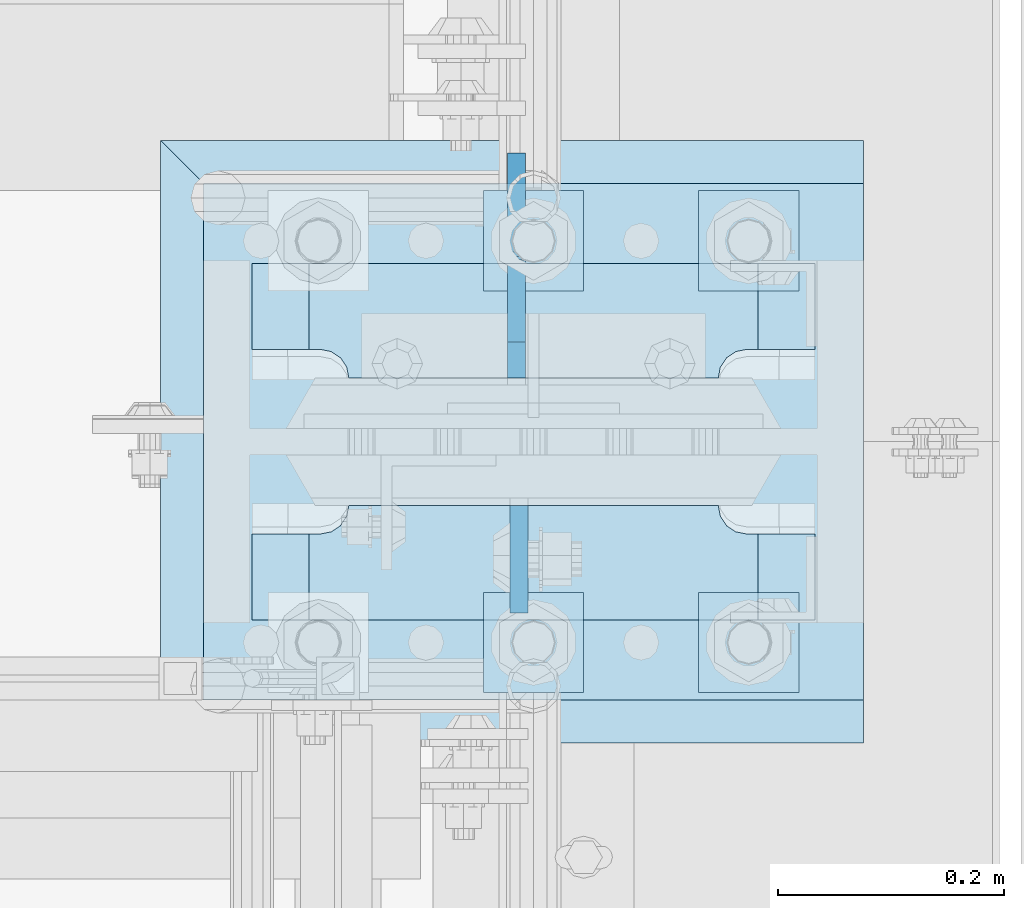
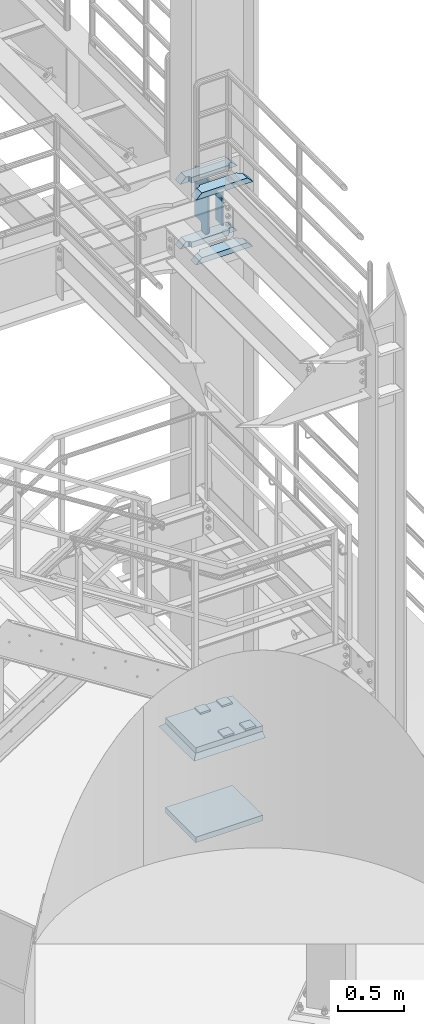
# One storey, part 1527 of 1876: 13 plates, 3 elements without a shape of their own.
"""IFC2X3 building model written with IfcOpenShell, lengths in millimetres."""

from ifc_helpers import new_model, si_unit, frame, origin_with_axes, place, context, subcontext, project, spatial, faceted_brep, material, type_object, element, aggregate, save


model = new_model("IFC2X3")

# Units and contexts
model_context = context("Model", 3, precision=1e-05, world=origin_with_axes())
body_context = subcontext(model_context, "Body", "Model", "MODEL_VIEW")
ifc_project = project(units=[si_unit("LENGTHUNIT", "METRE", prefix="MILLI"), si_unit("AREAUNIT", "SQUARE_METRE"), si_unit("VOLUMEUNIT", "CUBIC_METRE"), si_unit("MASSUNIT", "GRAM", prefix="KILO"), si_unit("TIMEUNIT", "SECOND"), si_unit("PLANEANGLEUNIT", "RADIAN"), si_unit("SOLIDANGLEUNIT", "STERADIAN"), si_unit("THERMODYNAMICTEMPERATUREUNIT", "DEGREE_CELSIUS"), si_unit("LUMINOUSINTENSITYUNIT", "LUMEN")], contexts=[model_context])

# Site, building, storey
site_placement = place(None, origin_with_axes())
site = spatial("IfcSite", under=ifc_project, at=site_placement, CompositionType="ELEMENT")
building_placement = place(site_placement, origin_with_axes())
building = spatial("IfcBuilding", under=site, at=building_placement, Name="Undefined", CompositionType="ELEMENT")
storey_placement = place(building_placement, origin_with_axes())
storey = spatial("IfcBuildingStorey", under=building, at=storey_placement, Name="Undefined", CompositionType="ELEMENT", Elevation=0.0)

# Assembly, plate
assembly_1_placement = place(storey_placement, origin_with_axes())
assembly_1 = element("IfcElementAssembly", 1, at=assembly_1_placement, inside=storey, Name="GROUT", AssemblyPlace="NOTDEFINED", PredefinedType="REINFORCEMENT_UNIT")
ifc_material_1 = material(Name="CONCRETE/Concrete_Undefined")
plate_type_1 = type_object("IfcPlateType", PredefinedType="NOTDEFINED")
plate_1_placement = place(assembly_1_placement, frame((7289.8, -4838.7, 19.05), z_axis=(0.0, 1.0, 0.0), x_axis=(1.0, 0.0, 0.0)))
plate_1 = element("IfcPlate", 2, at=plate_1_placement, type_object=plate_type_1, material=ifc_material_1, Name="GROUT", context=body_context, shape_type="Brep", body=[
    faceted_brep([(622.299804676334, 19.0499984735558, 533.400024414062), (622.299999999999, -19.05, 495.299999999985), (622.299999999984, -19.05, 38.1000000000167), (622.299804676334, 19.05, 0.0), (38.100000011611, -19.05, 495.299999988873), (-2.72848410531878e-12, 19.05, 533.400024414152), (-9.09494701772928e-13, 19.05, -1.81898940354586e-12), (38.1000000120275, -19.05, 38.1000000109725)], [[[0, 1, 2, 3]], [[4, 5, 6, 7]], [[6, 5, 0, 3]], [[7, 6, 3, 2]], [[2, 1, 4, 7]], [[5, 4, 1, 0]]]),
])
aggregate(assembly_1, [plate_1])

# Assembly, plates
assembly_2_placement = place(storey_placement, origin_with_axes())
assembly_2 = element("IfcElementAssembly", 3, at=assembly_2_placement, inside=storey, Name="COLUMN", AssemblyPlace="NOTDEFINED", PredefinedType="RIGID_FRAME")
ifc_material_2 = material(Name="STEEL/A572-50")
plate_type_2 = type_object("IfcPlateType", PredefinedType="NOTDEFINED")
plate_2_placement = place(assembly_2_placement, frame((7869.2375, -4628.35625, 4508.50002441406), z_axis=(-1.0, 0.0, 0.0), x_axis=(0.0, -1.0, 0.0)))
plate_2 = element("IfcPlate", 4, at=plate_2_placement, type_object=plate_type_2, material=ifc_material_2, Name="PLATE", context=body_context, shape_type="Brep", body=[
    faceted_brep([(101.599998474121, -25.3999999999996, 498.475006103516), (101.599998474121, 25.3999999999996, 447.975004579813), (25.3999996185303, 25.3999999999996, 447.975004579813), (25.3999996185303, -25.3999999999996, 498.475006103516), (23.4665397733534, -25.3999999999996, 428.429848211837), (25.3999996185303, -25.3999999999996, 438.150007247925), (25.3999996185303, 25.3999999999996, 438.150007247925), (23.4665397733534, 25.3999999999996, 428.429848211837), (17.9605119723965, -25.3999999999996, 420.189495275529), (17.9605119723965, 25.3999999999996, 420.189495275529), (9.72015903608917, -25.3999999999996, 414.683467474573), (9.72015903608917, 25.3999999999996, 414.683467474573), (0.0, -25.3999999999996, 412.750007629395), (0.0, 25.3999999999996, 412.750007629395), (0.0, -25.3999999999996, 85.7249984741211), (0.0, 25.3999999999996, 85.7249984741211), (9.72015903609099, -25.3999999999996, 83.7915386289451), (9.72015903609099, 25.3999999999996, 83.7915386289451), (17.9605119723983, -25.3999999999996, 78.2855108279891), (17.9605119723983, 25.3999999999996, 78.2855108279891), (23.4665397733552, -25.3999999999996, 70.0451578916818), (23.4665397733552, 25.3999999999996, 70.0451578916818), (25.3999996185303, -25.3999999999996, 60.3249988555908), (25.3999996185303, 25.3999999999996, 60.3249988555908), (25.3999996185303, 25.3999999999996, 50.5000015237028), (25.3999996185303, -25.3999999999996, 0.0), (101.599998474121, 25.3999999999996, 50.5000015237028), (101.599998474121, -25.3999999999996, 0.0)], [[[0, 1, 2, 3]], [[4, 5, 6, 7]], [[8, 4, 7, 9]], [[10, 8, 9, 11]], [[12, 10, 11, 13]], [[14, 12, 13, 15]], [[16, 14, 15, 17]], [[18, 16, 17, 19]], [[20, 18, 19, 21]], [[22, 20, 21, 23]], [[22, 23, 24, 25]], [[26, 27, 25, 24]], [[5, 4, 8, 10, 12, 14, 16, 18, 20, 22, 25, 27, 0, 3]], [[6, 5, 3, 2]], [[26, 24, 23, 21, 19, 17, 15, 13, 11, 9, 7, 6, 2, 1]], [[27, 26, 1, 0]]]),
])
plate_3_placement = place(assembly_2_placement, frame((7869.2375, -4628.35625, 5105.4), z_axis=(-1.0, 0.0, 0.0), x_axis=(0.0, -1.0, 0.0)))
plate_3 = element("IfcPlate", 5, at=plate_3_placement, type_object=plate_type_2, material=ifc_material_2, Name="PLATE", context=body_context, shape_type="Brep", body=[
    faceted_brep([(101.599998474121, -25.3999999999996, 498.475006103516), (101.599998474121, 25.3999999999996, 447.975004579813), (25.3999996185303, 25.3999999999996, 447.975004579813), (25.3999996185303, -25.3999999999996, 498.475006103516), (23.4665397733534, -25.3999999999996, 428.429848211837), (25.3999996185303, -25.3999999999996, 438.150007247925), (25.3999996185303, 25.3999999999996, 438.150007247925), (23.4665397733534, 25.3999999999996, 428.429848211837), (17.9605119723965, -25.3999999999996, 420.189495275529), (17.9605119723965, 25.3999999999996, 420.189495275529), (9.72015903608917, -25.3999999999996, 414.683467474573), (9.72015903608917, 25.3999999999996, 414.683467474573), (0.0, -25.3999999999996, 412.750007629395), (0.0, 25.3999999999996, 412.750007629395), (0.0, -25.3999999999996, 85.7249984741211), (0.0, 25.3999999999996, 85.7249984741211), (9.72015903609099, -25.3999999999996, 83.7915386289451), (9.72015903609099, 25.3999999999996, 83.7915386289451), (17.9605119723983, -25.3999999999996, 78.2855108279891), (17.9605119723983, 25.3999999999996, 78.2855108279891), (23.4665397733552, -25.3999999999996, 70.0451578916818), (23.4665397733552, 25.3999999999996, 70.0451578916818), (25.3999996185303, -25.3999999999996, 60.3249988555908), (25.3999996185303, 25.3999999999996, 60.3249988555908), (25.3999996185303, 25.3999999999996, 50.5000015237028), (25.3999996185303, -25.3999999999996, 0.0), (101.599998474121, 25.3999999999996, 50.5000015237028), (101.599998474121, -25.3999999999996, 0.0)], [[[0, 1, 2, 3]], [[4, 5, 6, 7]], [[8, 4, 7, 9]], [[10, 8, 9, 11]], [[12, 10, 11, 13]], [[14, 12, 13, 15]], [[16, 14, 15, 17]], [[18, 16, 17, 19]], [[20, 18, 19, 21]], [[22, 20, 21, 23]], [[22, 23, 24, 25]], [[26, 27, 25, 24]], [[5, 4, 8, 10, 12, 14, 16, 18, 20, 22, 25, 27, 0, 3]], [[6, 5, 3, 2]], [[26, 24, 23, 21, 19, 17, 15, 13, 11, 9, 7, 6, 2, 1]], [[27, 26, 1, 0]]]),
])
plate_4_placement = place(assembly_2_placement, frame((7869.2375, -4414.04375, 4508.50002441406), z_axis=(-1.0, 0.0, 0.0), x_axis=(0.0, -1.0, 0.0)))
plate_4 = element("IfcPlate", 6, at=plate_4_placement, type_object=plate_type_2, material=ifc_material_2, Name="PLATE", context=body_context, shape_type="Brep", body=[
    faceted_brep([(76.1999988555908, -25.3999999999996, 498.475006103516), (76.1999988555908, 25.3999999999996, 447.975004579812), (0.0, 25.3999999999996, 447.975004579812), (0.0, -25.3999999999996, 498.475006103516), (76.1999988555908, 25.3999999999996, 50.5000015237032), (76.1999988555908, -25.3999999999996, 0.0), (0.0, -25.3999996185375, 0.0), (0.0, 25.3999999999996, 50.5000015237032), (76.1999988555908, 25.3999999999996, 60.3249988555908), (76.1999988555908, -25.3999999999996, 60.3249988555908), (78.1334587007668, -25.3999999999996, 70.045157891682), (78.1334587007668, 25.3999999999996, 70.045157891682), (83.6394865017228, -25.3999999999996, 78.2855108279893), (83.6394865017228, 25.3999999999996, 78.2855108279893), (91.8798394380301, -25.3999999999996, 83.7915386289454), (91.8798394380301, 25.3999999999996, 83.7915386289454), (101.599998474121, -25.3999999999996, 85.7249984741211), (101.599998474121, 25.3999999999996, 85.7249984741211), (101.599998474121, -25.3999999999996, 412.750007629395), (101.599998474121, 25.3999999999996, 412.750007629395), (91.8798394380301, -25.3999999999996, 414.68346747457), (91.8798394380301, 25.3999999999996, 414.68346747457), (83.6394865017219, -25.3999999999996, 420.189495275526), (83.6394865017219, 25.3999999999996, 420.189495275526), (78.1334587007659, -25.3999999999996, 428.429848211834), (78.1334587007659, 25.3999999999996, 428.429848211834), (76.1999988555908, -25.3999999999996, 438.150007247925), (76.1999988555908, 25.3999999999996, 438.150007247925)], [[[0, 1, 2, 3]], [[4, 5, 6, 7]], [[8, 9, 5, 4]], [[10, 9, 8, 11]], [[12, 10, 11, 13]], [[14, 12, 13, 15]], [[16, 14, 15, 17]], [[18, 16, 17, 19]], [[20, 18, 19, 21]], [[22, 20, 21, 23]], [[24, 22, 23, 25]], [[26, 24, 25, 27]], [[6, 5, 9, 10, 12, 14, 16, 18, 20, 22, 24, 26, 0, 3]], [[7, 6, 3, 2]], [[27, 25, 23, 21, 19, 17, 15, 13, 11, 8, 4, 7, 2, 1]], [[26, 27, 1, 0]]]),
])
plate_5_placement = place(assembly_2_placement, frame((7869.2375, -4414.04375, 5105.4), z_axis=(-1.0, 0.0, 0.0), x_axis=(0.0, -1.0, 0.0)))
plate_5 = element("IfcPlate", 7, at=plate_5_placement, type_object=plate_type_2, material=ifc_material_2, Name="PLATE", context=body_context, shape_type="Brep", body=[
    faceted_brep([(76.1999988555908, -25.3999999999996, 498.475006103516), (76.1999988555908, 25.3999999999996, 447.975004579812), (0.0, 25.3999999999996, 447.975004579812), (0.0, -25.3999999999996, 498.475006103516), (76.1999988555908, 25.3999999999996, 50.5000015237032), (76.1999988555908, -25.3999999999996, 0.0), (0.0, -25.3999996185375, 0.0), (0.0, 25.3999999999996, 50.5000015237032), (76.1999988555908, 25.3999999999996, 60.3249988555908), (76.1999988555908, -25.3999999999996, 60.3249988555908), (78.1334587007668, -25.3999999999996, 70.045157891682), (78.1334587007668, 25.3999999999996, 70.045157891682), (83.6394865017228, -25.3999999999996, 78.2855108279893), (83.6394865017228, 25.3999999999996, 78.2855108279893), (91.8798394380301, -25.3999999999996, 83.7915386289454), (91.8798394380301, 25.3999999999996, 83.7915386289454), (101.599998474121, -25.3999999999996, 85.7249984741211), (101.599998474121, 25.3999999999996, 85.7249984741211), (101.599998474121, -25.3999999999996, 412.750007629395), (101.599998474121, 25.3999999999996, 412.750007629395), (91.8798394380301, -25.3999999999996, 414.68346747457), (91.8798394380301, 25.3999999999996, 414.68346747457), (83.6394865017219, -25.3999999999996, 420.189495275526), (83.6394865017219, 25.3999999999996, 420.189495275526), (78.1334587007659, -25.3999999999996, 428.429848211834), (78.1334587007659, 25.3999999999996, 428.429848211834), (76.1999988555908, -25.3999999999996, 438.150007247925), (76.1999988555908, 25.3999999999996, 438.150007247925)], [[[0, 1, 2, 3]], [[4, 5, 6, 7]], [[8, 9, 5, 4]], [[10, 9, 8, 11]], [[12, 10, 11, 13]], [[14, 12, 13, 15]], [[16, 14, 15, 17]], [[18, 16, 17, 19]], [[20, 18, 19, 21]], [[22, 20, 21, 23]], [[24, 22, 23, 25]], [[26, 24, 25, 27]], [[6, 5, 9, 10, 12, 14, 16, 18, 20, 22, 24, 26, 0, 3]], [[7, 6, 3, 2]], [[27, 25, 23, 21, 19, 17, 15, 13, 11, 8, 4, 7, 2, 1]], [[26, 27, 1, 0]]]),
])
ifc_material_3 = material(Name="STEEL/A36")
plate_type_3 = type_object("IfcPlateType", PredefinedType="NOTDEFINED")
plate_6_placement = place(assembly_2_placement, frame((7607.30049991608, -4628.35625, 5067.3), z_axis=(0.0, -1.0, 0.0), x_axis=(0.0, 0.0, -1.0)))
plate_6 = element("IfcPlate", 8, at=plate_6_placement, type_object=plate_type_3, material=ifc_material_3, Name="PLATE", context=body_context, shape_type="Brep", body=[
    faceted_brep([(0.0, -7.9375, 0.0), (0.0, -7.9375, 95.25), (0.0, 7.9375, 95.25), (0.0, 7.9375, 0.0), (304.799987792969, -7.9375, 95.25), (304.799987792969, 7.9375, 95.25), (304.799987792969, -7.9375, 0.0), (304.799987792969, 7.9375, 0.0)], [[[0, 1, 2, 3]], [[1, 4, 5, 2]], [[4, 6, 7, 5]], [[6, 0, 3, 7]], [[5, 7, 3, 2]], [[6, 4, 1, 0]]]),
])
plate_type_4 = type_object("IfcPlateType", PredefinedType="NOTDEFINED")
plate_7_placement = place(assembly_2_placement, frame((7604.91949987411, -4515.64375, 5080.0), z_axis=(0.0, 1.0, 0.0), x_axis=(0.0, 0.0, -1.0)))
plate_7 = element("IfcPlate", 9, at=plate_7_placement, type_object=plate_type_4, material=ifc_material_3, Name="PLATE", context=body_context, shape_type="Brep", body=[
    faceted_brep([(469.900012207031, -7.9375, 199.231247384208), (469.900012207031, -7.9375, 116.681246757507), (469.900012207031, 7.9375, 116.681246757507), (469.900012207031, 7.9375, 199.231246948242), (470.866742129619, -7.9375, 111.821167239462), (470.866742129619, 7.9375, 111.821167239462), (473.619756030097, -7.9375, 107.700990771308), (473.619756030097, 7.9375, 107.700990771308), (477.739932498251, -7.9375, 104.94797687083), (477.739932498251, 7.9375, 104.94797687083), (482.600012016296, -7.9375, 103.981246948242), (482.600012016296, 7.9375, 103.981246948242), (546.099975585938, -7.9375, 103.981246948242), (546.099975585938, 7.9375, 103.981246948242), (12.6999996185305, -7.9375, 199.231249999999), (12.6999996185305, 7.9375, 199.231246948242), (12.6999996185305, 7.9375, 116.681249809264), (12.6999996185305, -7.9375, 116.681249809264), (11.7332696959429, 7.9375, 111.821170291219), (11.7332696959429, -7.9375, 111.821170291219), (8.98025579546447, 7.9375, 107.700993823065), (8.98025579546447, -7.9375, 107.700993823065), (4.86007932731081, 7.9375, 104.947979922586), (4.86007932731081, -7.9375, 104.947979922586), (0.0, 7.9375, 103.981249999999), (0.0, -7.9375, 103.981249999999), (0.0, 7.93749999999999, 31.75), (0.0, -7.93749999999998, 31.75), (31.75, -7.93749999999998, 0.0), (31.75, 7.93749999999999, 0.0), (514.349975585938, -7.9375, 0.0), (514.349975585938, 7.9375, 0.0), (546.099975585938, -7.9375, 31.75), (546.099975585938, 7.9375, 31.75)], [[[0, 1, 2, 3]], [[4, 5, 2, 1]], [[6, 7, 5, 4]], [[8, 9, 7, 6]], [[10, 11, 9, 8]], [[12, 13, 11, 10]], [[14, 15, 16, 17]], [[17, 16, 18, 19]], [[19, 18, 20, 21]], [[21, 20, 22, 23]], [[23, 22, 24, 25]], [[26, 27, 25, 24]], [[28, 27, 26, 29]], [[30, 28, 29, 31]], [[32, 30, 31, 33]], [[8, 6, 4, 1, 0, 14, 17, 19, 21, 23, 25, 27, 28, 30, 32, 12, 10]], [[15, 14, 0, 3]], [[33, 31, 29, 26, 24, 22, 20, 18, 16, 15, 3, 2, 5, 7, 9, 11, 13]], [[32, 33, 13, 12]]]),
])

assembly_3_placement = place(storey_placement, origin_with_axes())
assembly_3 = element("IfcElementAssembly", 10, at=assembly_3_placement, inside=storey, Name="TEMPLATE", AssemblyPlace="NOTDEFINED", PredefinedType="RIGID_FRAME")
plate_type_5 = type_object("IfcPlateType", PredefinedType="NOTDEFINED")
plate_8_placement = place(assembly_3_placement, frame((7766.05, -4705.35, 96.8375), z_axis=(0.0, -1.0, 0.0), x_axis=(1.0, 0.0, 0.0)))
plate_8 = element("IfcPlate", 11, at=plate_8_placement, type_object=plate_type_5, material=ifc_material_2, Name="PLATE WASHER", context=body_context, shape_type="Brep", body=[
    faceted_brep([(0.0, -7.9375, 0.0), (0.0, -7.9375, 88.9000015258789), (0.0, 7.9375, 88.9000015258789), (0.0, 7.9375, 0.0), (88.9000015258789, -7.9375, 88.9000015258789), (88.9000015258789, 7.9375, 88.9000015258789), (88.9000015258789, -7.9375, 0.0), (88.9000015258789, 7.9375, 0.0)], [[[0, 1, 2, 3]], [[1, 4, 5, 2]], [[4, 6, 7, 5]], [[6, 0, 3, 7]], [[5, 7, 3, 2]], [[6, 4, 1, 0]]]),
])
plate_9_placement = place(assembly_3_placement, frame((7766.05, -4349.75, 96.8375), z_axis=(0.0, -1.0, 0.0), x_axis=(1.0, 0.0, 0.0)))
plate_9 = element("IfcPlate", 12, at=plate_9_placement, type_object=plate_type_5, material=ifc_material_2, Name="PLATE WASHER", context=body_context, shape_type="Brep", body=[
    faceted_brep([(0.0, -7.9375, 0.0), (0.0, -7.9375, 88.9000015258789), (0.0, 7.9375, 88.9000015258789), (0.0, 7.9375, 0.0), (88.9000015258789, -7.9375, 88.9000015258789), (88.9000015258789, 7.9375, 88.9000015258789), (88.9000015258789, -7.9375, 0.0), (88.9000015258789, 7.9375, 0.0)], [[[0, 1, 2, 3]], [[1, 4, 5, 2]], [[4, 6, 7, 5]], [[6, 0, 3, 7]], [[5, 7, 3, 2]], [[6, 4, 1, 0]]]),
])
plate_10_placement = place(assembly_3_placement, frame((7575.55, -4705.35, 96.8375), z_axis=(0.0, -1.0, 0.0), x_axis=(1.0, 0.0, 0.0)))
plate_10 = element("IfcPlate", 13, at=plate_10_placement, type_object=plate_type_5, material=ifc_material_2, Name="PLATE WASHER", context=body_context, shape_type="Brep", body=[
    faceted_brep([(0.0, -7.9375, 0.0), (0.0, -7.9375, 88.9000015258789), (0.0, 7.9375, 88.9000015258789), (0.0, 7.9375, 0.0), (88.9000015258789, -7.9375, 88.9000015258789), (88.9000015258789, 7.9375, 88.9000015258789), (88.9000015258789, -7.9375, 0.0), (88.9000015258789, 7.9375, 0.0)], [[[0, 1, 2, 3]], [[1, 4, 5, 2]], [[4, 6, 7, 5]], [[6, 0, 3, 7]], [[5, 7, 3, 2]], [[6, 4, 1, 0]]]),
])
plate_11_placement = place(assembly_3_placement, frame((7575.55, -4349.75, 96.8375), z_axis=(0.0, -1.0, 0.0), x_axis=(1.0, 0.0, 0.0)))
plate_11 = element("IfcPlate", 14, at=plate_11_placement, type_object=plate_type_5, material=ifc_material_2, Name="PLATE WASHER", context=body_context, shape_type="Brep", body=[
    faceted_brep([(0.0, -7.9375, 0.0), (0.0, -7.9375, 88.9000015258789), (0.0, 7.9375, 88.9000015258789), (0.0, 7.9375, 0.0), (88.9000015258789, -7.9375, 88.9000015258789), (88.9000015258789, 7.9375, 88.9000015258789), (88.9000015258789, -7.9375, 0.0), (88.9000015258789, 7.9375, 0.0)], [[[0, 1, 2, 3]], [[1, 4, 5, 2]], [[4, 6, 7, 5]], [[6, 0, 3, 7]], [[5, 7, 3, 2]], [[6, 4, 1, 0]]]),
])
plate_type_6 = type_object("IfcPlateType", PredefinedType="NOTDEFINED")
plate_12_placement = place(assembly_3_placement, frame((7327.9, -4800.6, -762.0), z_axis=(0.0, 1.0, 0.0), x_axis=(1.0, 0.0, 0.0)))
plate_12 = element("IfcPlate", 15, at=plate_12_placement, type_object=plate_type_6, material=ifc_material_2, Name="PLATE", context=body_context, shape_type="Brep", body=[
    faceted_brep([(0.0, -25.3999996185375, 0.0), (0.0, -25.4, 457.200012207031), (0.0, 25.4, 457.200012207031), (0.0, 25.3999996185339, 9.09494701772928e-13), (584.200012207031, -25.4, 457.200012207031), (584.200012207031, 25.4, 457.200012207031), (584.200012207031, -25.4, 0.0), (584.200012207031, 25.4, 0.0)], [[[0, 1, 2, 3]], [[1, 4, 5, 2]], [[4, 6, 7, 5]], [[6, 0, 3, 7]], [[5, 7, 3, 2]], [[6, 4, 1, 0]]]),
])
aggregate(assembly_3, [plate_12, plate_8, plate_9, plate_10, plate_11])

# Plate
ifc_material_4 = material(Name="STEEL/A572-GR.50")
plate_13_placement = place(assembly_2_placement, frame((7327.9, -4800.6, 63.5), z_axis=(0.0, 1.0, 0.0), x_axis=(1.0, 0.0, 0.0)))
plate_13 = element("IfcPlate", 16, at=plate_13_placement, type_object=plate_type_6, material=ifc_material_4, Name="PLATE", context=body_context, shape_type="Brep", body=[
    faceted_brep([(0.0, -25.3999996185375, 0.0), (0.0, -25.4, 457.200012207031), (0.0, 25.4, 457.200012207031), (0.0, 25.3999996185339, 9.09494701772928e-13), (584.200012207031, -25.4, 457.200012207031), (584.200012207031, 25.4, 457.200012207031), (584.200012207031, -25.4, 0.0), (584.200012207031, 25.4, 0.0)], [[[0, 1, 2, 3]], [[1, 4, 5, 2]], [[4, 6, 7, 5]], [[6, 0, 3, 7]], [[5, 7, 3, 2]], [[6, 4, 1, 0]]]),
])

aggregate(assembly_2, [plate_6, plate_2, plate_3, plate_4, plate_5, plate_7, plate_13])

save(model, "model.ifc")
